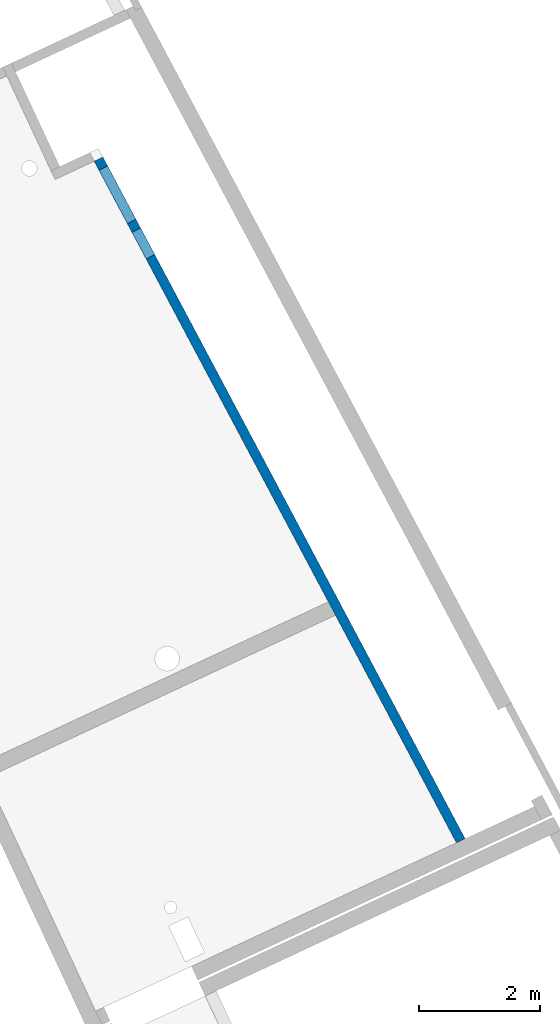
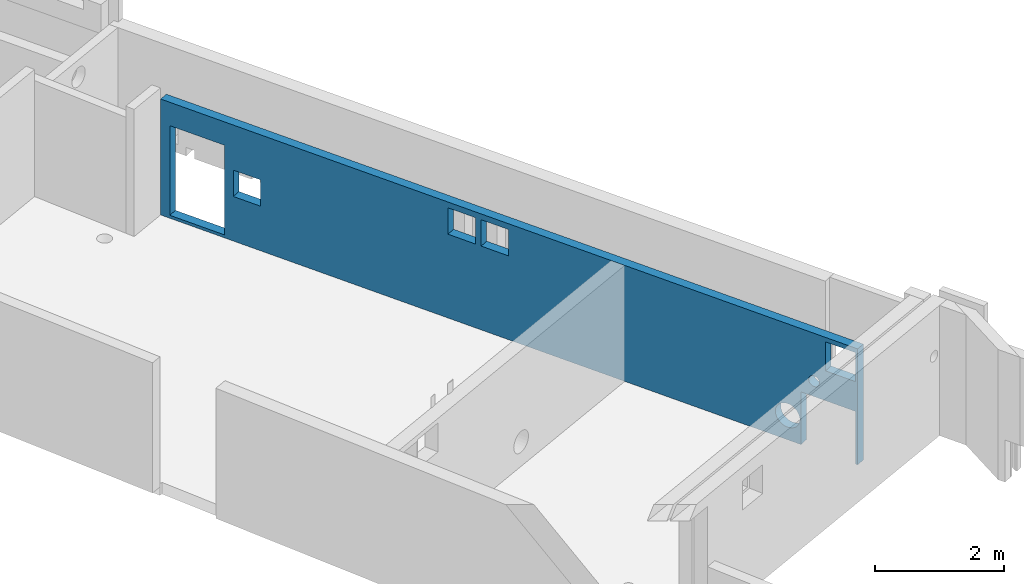
# One storey, part 11 of 13: 1 wall.
"""IFC2X3 building model written with IfcOpenShell, lengths in metres."""

from ifc_helpers import new_model, entity, si_unit, converted_unit, derived_unit, direction, frame, origin, place, context, subcontext, project, spatial, faceted_brep, material, layer, layer_set, type_object, element, save


model = new_model("IFC2X3")

# Units and contexts
model_context = context("Model", 3, precision=1e-05, world=origin(), true_north=direction((6.12303176911189e-17, 1.0)))
body_context = subcontext(model_context, "Body", "Model", "MODEL_VIEW")
ifc_project = project(units=[si_unit("LENGTHUNIT", "METRE"), si_unit("AREAUNIT", "SQUARE_METRE"), si_unit("VOLUMEUNIT", "CUBIC_METRE"), converted_unit("PLANEANGLEUNIT", "DEGREE", entity("IfcRatioMeasure", 0.0174532925199433), si_unit("PLANEANGLEUNIT", "RADIAN"), dimensions=[0, 0, 0, 0, 0, 0, 0]), si_unit("MASSUNIT", "GRAM", prefix="KILO"), derived_unit("MASSDENSITYUNIT", [(si_unit("MASSUNIT", "GRAM", prefix="KILO"), 1), (si_unit("LENGTHUNIT", "METRE"), -3)]), si_unit("TIMEUNIT", "SECOND"), si_unit("FREQUENCYUNIT", "HERTZ"), si_unit("THERMODYNAMICTEMPERATUREUNIT", "DEGREE_CELSIUS"), derived_unit("THERMALTRANSMITTANCEUNIT", [(si_unit("MASSUNIT", "GRAM", prefix="KILO"), 1), (si_unit("THERMODYNAMICTEMPERATUREUNIT", "KELVIN"), -1), (si_unit("TIMEUNIT", "SECOND"), -3)]), derived_unit("VOLUMETRICFLOWRATEUNIT", [(si_unit("LENGTHUNIT", "METRE"), 3), (si_unit("TIMEUNIT", "SECOND"), -1)]), si_unit("ELECTRICCURRENTUNIT", "AMPERE"), si_unit("ELECTRICVOLTAGEUNIT", "VOLT"), si_unit("POWERUNIT", "WATT"), si_unit("FORCEUNIT", "NEWTON", prefix="KILO"), si_unit("ILLUMINANCEUNIT", "LUX"), si_unit("LUMINOUSFLUXUNIT", "LUMEN"), si_unit("LUMINOUSINTENSITYUNIT", "CANDELA"), derived_unit("USERDEFINED", [(si_unit("MASSUNIT", "GRAM", prefix="KILO"), -1), (si_unit("LENGTHUNIT", "METRE"), -2), (si_unit("TIMEUNIT", "SECOND"), 3), (si_unit("LUMINOUSFLUXUNIT", "LUMEN"), 1)]), derived_unit("LINEARVELOCITYUNIT", [(si_unit("LENGTHUNIT", "METRE"), 1), (si_unit("TIMEUNIT", "SECOND"), -1)]), si_unit("PRESSUREUNIT", "PASCAL"), derived_unit("USERDEFINED", [(si_unit("LENGTHUNIT", "METRE"), -2), (si_unit("MASSUNIT", "GRAM", prefix="KILO"), 1), (si_unit("TIMEUNIT", "SECOND"), -2)])], contexts=[model_context])

# Site, building, storey
site_placement = place(None, frame((5.36960000000003, 43.3158000000006, 0.0), z_axis=(0.0, 0.0, 1.0), x_axis=(-0.422618261740703, 0.906307787036648, 0.0)))
site = spatial("IfcSite", under=ifc_project, at=site_placement, CompositionType="ELEMENT")
building_placement = place(site_placement, origin())
building = spatial("IfcBuilding", under=site, at=building_placement, CompositionType="ELEMENT")
storey_placement = place(building_placement, frame((0.0, 0.0, 2.56)))
storey = spatial("IfcBuildingStorey", under=building, at=storey_placement, CompositionType="ELEMENT", Elevation=2.56)

# Wall
ifc_material = material(Name="C30/37 XC1")
ifc_layer = layer(ifc_material, 0.16)
ifc_layer_set = layer_set([ifc_layer])
wall_type = type_object("IfcWallType", PredefinedType="NOTDEFINED", material=ifc_layer_set)
wall_placement = place(storey_placement, frame((20.6114923844275, 2.9143844706944, 0.0599999999999593), z_axis=(0.0, 0.0, 1.0), x_axis=(0.998640817744192, 0.0521202181040388, 0.0)))
element("IfcWall", 1, at=wall_placement, inside=storey, type_object=wall_type, context=body_context, shape_type="Brep", body=[
    faceted_brep([(4.27414834925875, 0.0800000000000008, 0.0), (4.52448860729538, 0.0800000000000008, 0.0), (12.7807072981416, 0.0800000000000002, 0.0), (12.7723567132782, -0.0799999999999997, 0.0), (1.04451730053056, -0.0799999999999991, 0.0), (1.04451730053057, 0.0800000000000008, 0.0), (0.0445173005305713, -0.0799999999999997, 0.0), (0.0, -0.0799999999999997, 0.0), (0.00835058486342103, 0.0800000000000008, 0.0), (0.0445173005305715, 0.0800000000000008, 0.0), (0.0445173005305626, -0.0799999999999997, 1.0), (0.0, -0.0799999999999997, 2.20000000000004), (0.0445173005304974, -0.0799999999999997, 1.56499758505844), (0.703965505094572, -0.0800000000000002, 1.29172844441043), (0.707372922465671, -0.0799999999999997, 1.26584653990017), (0.717362964716128, -0.0799999999999997, 1.24172844441043), (0.733254826975919, -0.0799999999999997, 1.22101776629177), (0.75396550509458, -0.0800000000000002, 1.20512590403198), (0.778083600584327, -0.0799999999999997, 1.19513586178152), (1.04451730053057, -0.0800000000000002, 1.0), (0.803965505094579, -0.0799999999999997, 1.19172844441043), (0.829847409604831, -0.0799999999999997, 1.19513586178152), (0.853965505094578, -0.0799999999999991, 1.20512590403198), (0.874676183213235, -0.0799999999999991, 1.22101776629177), (0.890568045473021, -0.0799999999999997, 1.24172844441043), (0.900558087723487, -0.0799999999999997, 1.26584653990018), (0.903965505094577, -0.0799999999999997, 1.29172844441043), (0.900558087723487, -0.0799999999999997, 1.31761034892068), (1.38642637710029, -0.0799999999999997, 0.667098438866411), (1.33886974593901, -0.0799999999999997, 0.683739223829277), (1.28880253579884, -0.0799999999999997, 0.689380443588367), (1.23873532565867, -0.0799999999999997, 0.683739223829277), (1.19117869449739, -0.0799999999999997, 0.667098438866411), (1.14851733038063, -0.0799999999999997, 0.640292527143674), (1.11289045224354, -0.0800000000000002, 0.604665649006582), (1.0860845405208, -0.0799999999999997, 0.562004284889818), (1.06944375555794, -0.0799999999999991, 0.514447653728538), (1.06380253579884, -0.0799999999999997, 0.464380443588367), (1.06944375555794, -0.0799999999999991, 0.414313233448195), (1.0860845405208, -0.0799999999999997, 0.366756602286915), (1.11289045224354, -0.0800000000000002, 0.324095238170151), (1.14851733038063, -0.0799999999999997, 0.28846836003306), (1.19117869449739, -0.0799999999999997, 0.261662448310322), (1.23873532565868, -0.0799999999999997, 0.245021663347456), (1.28880253579884, -0.0799999999999997, 0.239380443588367), (1.33886974593902, -0.0799999999999997, 0.245021663347457), (1.38642637710029, -0.0799999999999997, 0.261662448310323), (1.42908774121706, -0.0799999999999997, 0.288468360033061), (6.40403819375397, -0.0799999999999997, 1.59000000000004), (11.6096903452455, -0.0799999999999997, 0.056341491298684), (12.6096903452455, -0.0799999999999997, 0.056341491298684), (12.6096903452455, -0.0799999999999997, 1.75634149129868), (12.7723567132782, -0.0799999999999997, 2.20000000000004), (11.6096903452455, -0.0799999999999997, 1.75634149129868), (7.51194061385781, -0.0799999999999997, 2.09000000000004), (7.01194061385781, -0.0799999999999991, 2.09000000000004), (6.90403819375397, -0.0799999999999997, 2.09000000000004), (6.40403819375397, -0.0799999999999997, 2.09000000000004), (0.0445173005304974, -0.0799999999999997, 2.11499758505844), (0.594517300530496, -0.0799999999999997, 2.11499758505844), (1.42908774121706, -0.0799999999999997, 0.640292527143674), (1.46471461935415, -0.0799999999999997, 0.604665649006583), (1.49152053107689, -0.0800000000000002, 0.562004284889818), (7.01194061385781, -0.0799999999999991, 1.59000000000004), (6.90403819375397, -0.0799999999999997, 1.59000000000004), (11.4466245238561, -0.0799999999999997, 0.845300133582468), (7.51194061385781, -0.0799999999999997, 1.59000000000004), (10.9466245238561, -0.0799999999999991, 0.845300133582468), (10.9466245238561, -0.0799999999999991, 1.34530013358247), (11.4466245238561, -0.0799999999999997, 1.34530013358247), (1.46471461935415, -0.0799999999999997, 0.324095238170152), (1.49152053107689, -0.0800000000000002, 0.366756602286917), (1.50816131603975, -0.0799999999999997, 0.414313233448197), (1.51380253579884, -0.0799999999999997, 0.464380443588368), (1.50816131603975, -0.0799999999999997, 0.514447653728539), (0.890568045473021, -0.0799999999999997, 1.34172844441043), (0.594517300530496, -0.0799999999999997, 1.56499758505844), (0.707372922465671, -0.0799999999999997, 1.31761034892068), (0.717362964716128, -0.0799999999999997, 1.34172844441043), (0.733254826975919, -0.0799999999999997, 1.36243912252908), (0.75396550509458, -0.0800000000000002, 1.37833098478887), (0.778083600584323, -0.0799999999999997, 1.38832102703933), (0.803965505094579, -0.0799999999999997, 1.39172844441043), (0.829847409604831, -0.0799999999999997, 1.38832102703933), (0.853965505094578, -0.0799999999999991, 1.37833098478887), (0.874676183213231, -0.0799999999999997, 1.36243912252908), (12.6096903452456, 0.0800000000000002, 0.056341491298684), (12.6096903452455, 0.0800000000000008, 1.75634149129868), (11.6096903452456, 0.0800000000000008, 0.056341491298684), (12.7807072981416, 0.0800000000000002, 2.20000000000004), (7.51194061385781, 0.0800000000000008, 1.59000000000004), (7.01194061385781, 0.0800000000000008, 1.59000000000004), (6.90403819375397, 0.0800000000000008, 1.59000000000004), (6.40403819375397, 0.0800000000000008, 1.59000000000004), (4.52448860729538, 0.0800000000000008, 2.20000000000004), (4.27414834925875, 0.0800000000000002, 2.20000000000004), (1.49152053107689, 0.0800000000000002, 0.562004284889818), (1.50816131603976, 0.0800000000000002, 0.514447653728539), (1.51380253579884, 0.0800000000000008, 0.464380443588368), (1.50816131603976, 0.0800000000000002, 0.414313233448197), (1.49152053107689, 0.0800000000000002, 0.366756602286917), (1.46471461935415, 0.0800000000000008, 0.324095238170152), (1.42908774121706, 0.0800000000000008, 0.288468360033061), (1.38642637710029, 0.0800000000000008, 0.261662448310323), (1.33886974593901, 0.0800000000000002, 0.245021663347457), (1.28880253579884, 0.0800000000000002, 0.239380443588367), (1.23873532565867, 0.0800000000000008, 0.245021663347456), (1.19117869449739, 0.0800000000000008, 0.261662448310322), (1.14851733038063, 0.0800000000000002, 0.28846836003306), (1.11289045224354, 0.0800000000000002, 0.324095238170151), (1.0860845405208, 0.0800000000000002, 0.366756602286915), (1.06944375555793, 0.0800000000000008, 0.414313233448195), (1.06380253579884, 0.0800000000000008, 0.464380443588365), (1.04451730053057, 0.0800000000000008, 1.0), (1.06944375555793, 0.0800000000000008, 0.514447653728538), (1.0860845405208, 0.0800000000000002, 0.562004284889818), (1.11289045224354, 0.0800000000000002, 0.604665649006582), (1.14851733038063, 0.0800000000000002, 0.640292527143674), (1.19117869449739, 0.0800000000000008, 0.667098438866411), (1.23873532565867, 0.0800000000000008, 0.683739223829277), (1.28880253579884, 0.0800000000000002, 0.689380443588367), (1.33886974593901, 0.0800000000000002, 0.683739223829277), (1.38642637710029, 0.0800000000000008, 0.667098438866411), (0.900558087723483, 0.0800000000000002, 1.31761034892068), (0.903965505094573, 0.0800000000000002, 1.29172844441043), (0.900558087723483, 0.0800000000000002, 1.26584653990018), (0.890568045473017, 0.0800000000000002, 1.24172844441043), (0.874676183213231, 0.0800000000000002, 1.22101776629177), (0.853965505094574, 0.0800000000000008, 1.20512590403198), (0.829847409604827, 0.0800000000000002, 1.19513586178152), (0.803965505094575, 0.0800000000000008, 1.19172844441043), (0.778083600584323, 0.0799999999999997, 1.19513586178152), (0.0445173005305671, 0.0800000000000008, 1.0), (0.753965505094576, 0.0800000000000002, 1.20512590403198), (0.733254826975923, 0.0800000000000008, 1.22101776629177), (0.717362964716133, 0.0800000000000002, 1.24172844441043), (0.707372922465667, 0.0800000000000008, 1.26584653990017), (0.703965505094577, 0.0800000000000002, 1.29172844441043), (0.0445173005304933, 0.0800000000000002, 1.56499758505844), (0.00835058486342536, 0.0800000000000008, 2.20000000000004), (0.0445173005304933, 0.0800000000000002, 2.11499758505844), (0.594517300530496, 0.0800000000000002, 2.11499758505844), (1.46471461935415, 0.0800000000000008, 0.604665649006583), (1.42908774121706, 0.0800000000000008, 0.640292527143674), (0.890568045473017, 0.0800000000000002, 1.34172844441043), (0.874676183213227, 0.0800000000000002, 1.36243912252908), (0.853965505094574, 0.0800000000000008, 1.37833098478887), (0.829847409604827, 0.0800000000000002, 1.38832102703933), (0.594517300530496, 0.0800000000000002, 1.56499758505844), (0.803965505094575, 0.0800000000000008, 1.39172844441043), (0.778083600584323, 0.0799999999999997, 1.38832102703933), (0.753965505094576, 0.0800000000000002, 1.37833098478887), (0.733254826975923, 0.0800000000000008, 1.36243912252908), (0.717362964716133, 0.0800000000000002, 1.34172844441043), (0.707372922465667, 0.0800000000000008, 1.31761034892068), (7.51194061385781, 0.0800000000000008, 2.09000000000004), (7.01194061385781, 0.0800000000000008, 2.09000000000004), (6.40403819375397, 0.0800000000000008, 2.09000000000004), (6.90403819375397, 0.0800000000000008, 2.09000000000004), (10.9466245238561, 0.0800000000000002, 0.845300133582468), (10.9466245238561, 0.0800000000000002, 1.34530013358247), (11.6096903452456, 0.0800000000000008, 1.75634149129868), (11.4466245238561, 0.0800000000000002, 1.34530013358247), (11.4466245238561, 0.0800000000000002, 0.845300133582468)], [[[0, 1, 2, 3, 4, 5]], [[6, 7, 8, 9]], [[7, 6, 10]], [[7, 10, 11]], [[11, 10, 12]], [[12, 10, 13]], [[13, 10, 14]], [[10, 15, 14]], [[16, 15, 10]], [[16, 10, 17]], [[18, 17, 10]], [[10, 19, 18]], [[20, 18, 19]], [[21, 20, 19]], [[21, 19, 22]], [[19, 23, 22]], [[24, 23, 19]], [[24, 19, 25]], [[26, 25, 19]], [[27, 26, 19]], [[28, 27, 19]], [[28, 19, 29]], [[29, 19, 30]], [[30, 19, 31]], [[32, 31, 19]], [[33, 32, 19]], [[34, 33, 19]], [[34, 19, 35]], [[36, 35, 19]], [[19, 37, 36]], [[37, 19, 4]], [[38, 37, 4]], [[39, 38, 4]], [[40, 39, 4]], [[4, 41, 40]], [[42, 41, 4]], [[43, 42, 4]], [[43, 4, 44]], [[44, 4, 45]], [[45, 4, 46]], [[46, 4, 47]], [[48, 47, 4]], [[4, 49, 48]], [[4, 3, 49]], [[49, 3, 50]], [[50, 3, 51]], [[52, 51, 3]], [[53, 51, 52]], [[53, 52, 54]], [[55, 54, 52]], [[55, 52, 56]], [[57, 56, 52]], [[57, 52, 11]], [[58, 11, 12]], [[11, 58, 59]], [[11, 59, 57]], [[59, 60, 57]], [[57, 60, 61]], [[57, 61, 62]], [[57, 62, 48]], [[56, 63, 55]], [[64, 63, 56]], [[63, 64, 49]], [[48, 49, 64]], [[49, 53, 65]], [[63, 49, 66]], [[66, 49, 67]], [[49, 65, 67]], [[68, 66, 67]], [[54, 66, 68]], [[53, 68, 69]], [[68, 53, 54]], [[69, 65, 53]], [[47, 48, 70]], [[48, 71, 70]], [[72, 71, 48]], [[48, 73, 72]], [[48, 74, 73]], [[48, 62, 74]], [[60, 27, 28]], [[75, 27, 60]], [[76, 12, 13]], [[13, 77, 76]], [[77, 78, 76]], [[78, 79, 76]], [[76, 79, 80]], [[80, 81, 76]], [[81, 82, 76]], [[82, 83, 76]], [[83, 59, 76]], [[83, 84, 59]], [[85, 59, 84]], [[85, 75, 59]], [[59, 75, 60]], [[2, 86, 87]], [[86, 2, 88]], [[1, 88, 2]], [[87, 89, 2]], [[88, 1, 90]], [[1, 91, 90]], [[91, 1, 92]], [[93, 92, 1]], [[1, 94, 93]], [[1, 0, 94]], [[0, 95, 94]], [[95, 0, 96]], [[97, 96, 0]], [[98, 97, 0]], [[98, 0, 99]], [[100, 99, 0]], [[0, 101, 100]], [[101, 0, 102]], [[103, 102, 0]], [[5, 103, 0]], [[5, 104, 103]], [[105, 104, 5]], [[106, 105, 5]], [[107, 106, 5]], [[108, 107, 5]], [[109, 108, 5]], [[5, 110, 109]], [[110, 5, 111]], [[111, 5, 112]], [[113, 112, 5]], [[112, 113, 114]], [[113, 115, 114]], [[116, 115, 113]], [[116, 113, 117]], [[118, 117, 113]], [[119, 118, 113]], [[113, 120, 119]], [[120, 113, 121]], [[121, 113, 122]], [[122, 113, 123]], [[124, 123, 113]], [[125, 124, 113]], [[113, 126, 125]], [[126, 113, 127]], [[127, 113, 128]], [[128, 113, 129]], [[129, 113, 130]], [[113, 131, 130]], [[132, 131, 113]], [[132, 133, 131]], [[134, 133, 132]], [[132, 135, 134]], [[132, 136, 135]], [[136, 132, 137]], [[138, 137, 132]], [[139, 138, 132]], [[132, 8, 139]], [[132, 9, 8]], [[138, 139, 140]], [[140, 139, 141]], [[141, 139, 95]], [[95, 96, 142]], [[142, 143, 95]], [[144, 95, 143]], [[141, 95, 144]], [[144, 145, 141]], [[143, 123, 144]], [[145, 146, 141]], [[146, 147, 141]], [[148, 141, 147]], [[147, 149, 148]], [[149, 150, 148]], [[150, 151, 148]], [[148, 151, 152]], [[152, 153, 148]], [[153, 154, 148]], [[154, 137, 148]], [[137, 138, 148]], [[122, 123, 143]], [[89, 155, 94]], [[94, 155, 156]], [[93, 94, 157]], [[157, 94, 158]], [[158, 94, 156]], [[91, 158, 156]], [[91, 92, 158]], [[159, 88, 90]], [[159, 90, 160]], [[155, 160, 90]], [[160, 155, 161]], [[162, 160, 161]], [[88, 159, 163]], [[163, 161, 88]], [[162, 161, 163]], [[89, 87, 161]], [[161, 155, 89]], [[52, 3, 2, 89]], [[139, 8, 7, 11]], [[94, 95, 139, 11, 52, 89]], [[55, 63, 91, 156]], [[54, 55, 156, 155]], [[56, 57, 157, 158]], [[66, 54, 155, 90]], [[63, 66, 90, 91]], [[48, 64, 92, 93]], [[57, 48, 93, 157]], [[64, 56, 158, 92]], [[58, 12, 138, 140]], [[132, 10, 6, 9]], [[59, 58, 140, 141]], [[76, 59, 141, 148]], [[12, 76, 148, 138]], [[68, 67, 159, 160]], [[69, 68, 160, 162]], [[65, 69, 162, 163]], [[67, 65, 163, 159]], [[49, 88, 161, 53]], [[51, 87, 86, 50]], [[50, 86, 88, 49]], [[51, 53, 161, 87]], [[5, 4, 19, 113]], [[132, 113, 19, 10]], [[25, 26, 124, 125]], [[25, 125, 126, 24]], [[22, 23, 127, 128]], [[127, 23, 24, 126]], [[21, 22, 128, 129]], [[129, 130, 20, 21]], [[17, 18, 131, 133]], [[17, 133, 134, 16]], [[14, 15, 135, 136]], [[135, 15, 16, 134]], [[13, 14, 136, 137]], [[20, 130, 131, 18]], [[77, 13, 137, 154]], [[78, 77, 154, 153]], [[80, 79, 152, 151]], [[81, 80, 151, 150]], [[153, 152, 79, 78]], [[150, 149, 82, 81]], [[84, 83, 147, 146]], [[84, 146, 145, 85]], [[27, 75, 144, 123]], [[144, 75, 85, 145]], [[26, 27, 123, 124]], [[82, 149, 147, 83]], [[72, 73, 98, 99]], [[72, 99, 100, 71]], [[103, 46, 47, 102]], [[47, 70, 101, 102]], [[70, 71, 100, 101]], [[45, 46, 103, 104]], [[104, 105, 44, 45]], [[42, 43, 106, 107]], [[42, 107, 108, 41]], [[111, 38, 39, 110]], [[39, 40, 109, 110]], [[40, 41, 108, 109]], [[37, 38, 111, 112]], [[105, 106, 43, 44]], [[37, 112, 114, 36]], [[36, 114, 115, 35]], [[117, 118, 32, 33]], [[34, 35, 115, 116]], [[119, 31, 32, 118]], [[34, 116, 117, 33]], [[119, 120, 30, 31]], [[28, 29, 121, 122]], [[28, 122, 143, 60]], [[97, 74, 62, 96]], [[62, 61, 142, 96]], [[61, 60, 143, 142]], [[73, 74, 97, 98]], [[120, 121, 29, 30]]]),
])

save(model, "model.ifc")
